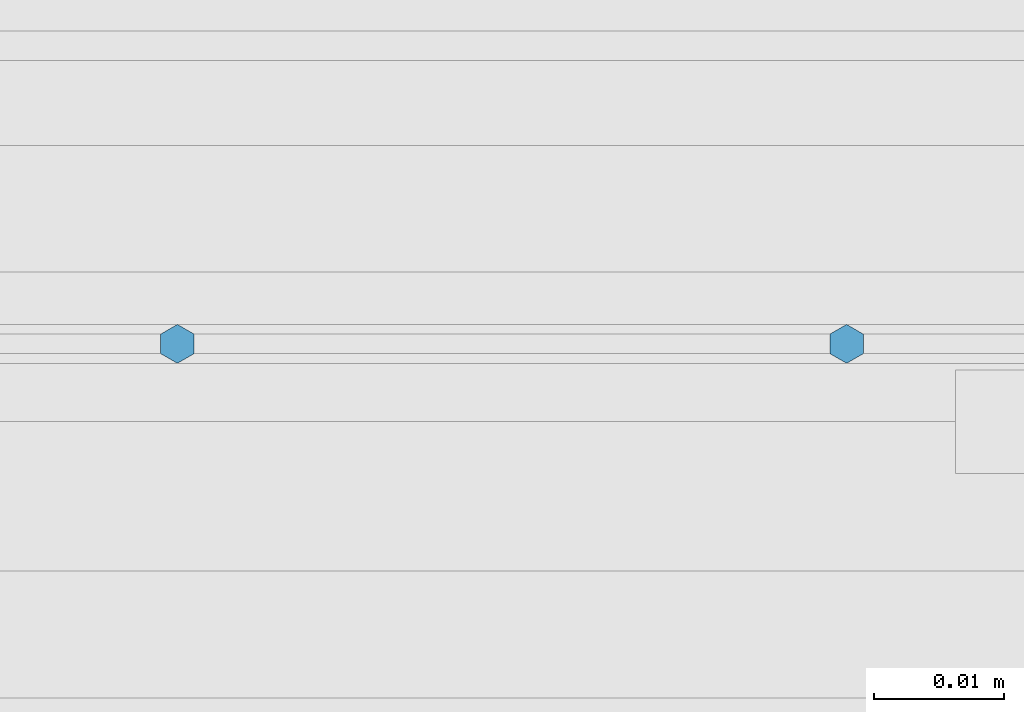
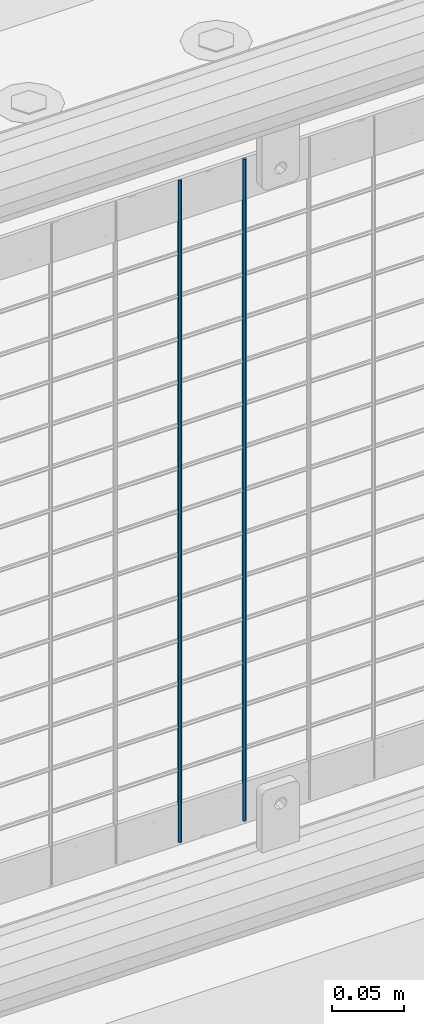
# One storey, part 54 of 193: 2 columns.
"""IFC2X3 building model written with IfcOpenShell, lengths in millimetres."""

from ifc_helpers import new_model, si_unit, frame, origin_with_axes, place, context, subcontext, project, spatial, faceted_brep, material, type_object, element, save


model = new_model("IFC2X3")

# Units and contexts
model_context = context("Model", 3, precision=1e-05, world=origin_with_axes())
body_context = subcontext(model_context, "Body", "Model", "MODEL_VIEW")
ifc_project = project(units=[si_unit("LENGTHUNIT", "METRE", prefix="MILLI"), si_unit("AREAUNIT", "SQUARE_METRE"), si_unit("VOLUMEUNIT", "CUBIC_METRE"), si_unit("MASSUNIT", "GRAM", prefix="KILO"), si_unit("TIMEUNIT", "SECOND"), si_unit("PLANEANGLEUNIT", "RADIAN"), si_unit("SOLIDANGLEUNIT", "STERADIAN"), si_unit("THERMODYNAMICTEMPERATUREUNIT", "DEGREE_CELSIUS"), si_unit("LUMINOUSINTENSITYUNIT", "LUMEN")], contexts=[model_context])

# Site, building, storey
site_placement = place(None, origin_with_axes())
site = spatial("IfcSite", under=ifc_project, at=site_placement, CompositionType="ELEMENT")
building_placement = place(site_placement, origin_with_axes())
building = spatial("IfcBuilding", under=site, at=building_placement, Name="Standard", CompositionType="ELEMENT")
storey_placement = place(building_placement, origin_with_axes())
storey = spatial("IfcBuildingStorey", under=building, at=storey_placement, Name="Undefined", CompositionType="ELEMENT", Elevation=0.0)

# Columns
ifc_material = material(Name="Misc_Undefined")
column_type = type_object("IfcColumnType", Name="D3", PredefinedType="NOTDEFINED")
for number, where, z_axis, x_axis in (
    (1, (-41387.415, 28670.5, 353.02), (-1.0, 0.0, 0.0), (0.0, 0.0, 1.0)),
    (2, (-41439.07, 28670.5, 353.02), (-1.0, 0.0, 0.0), (0.0, 0.0, 1.0)),
):
    element("IfcColumn", number, at=place(storey_placement, frame(where, z_axis=z_axis, x_axis=x_axis)), inside=storey, type_object=column_type, material=ifc_material, ObjectType="D3", context=body_context, shape_type="Brep", body=[
        faceted_brep([(0.0, -1.49999999999636, 3.63797880709171e-12), (0.0, -0.75, -1.29903810567669), (560.0, -0.75, -1.29903810567703), (560.0, -1.5, 0.0), (0.0, 0.75, -1.29903810567669), (560.0, 0.75, -1.29903810567703), (0.0, 1.50000000000364, 7.27595761418343e-12), (560.0, 1.5, 0.0), (0.0, 0.75, 1.29903810567669), (560.0, 0.75, 1.29903810567703), (0.0, -0.75, 1.29903810567669), (560.0, -0.75, 1.29903810567703)], [[[0, 1, 2, 3]], [[1, 4, 5, 2]], [[4, 6, 7, 5]], [[6, 8, 9, 7]], [[8, 10, 11, 9]], [[10, 0, 3, 11]], [[5, 7, 9, 11, 3, 2]], [[10, 8, 6, 4, 1, 0]]]),
    ])

save(model, "model.ifc")
